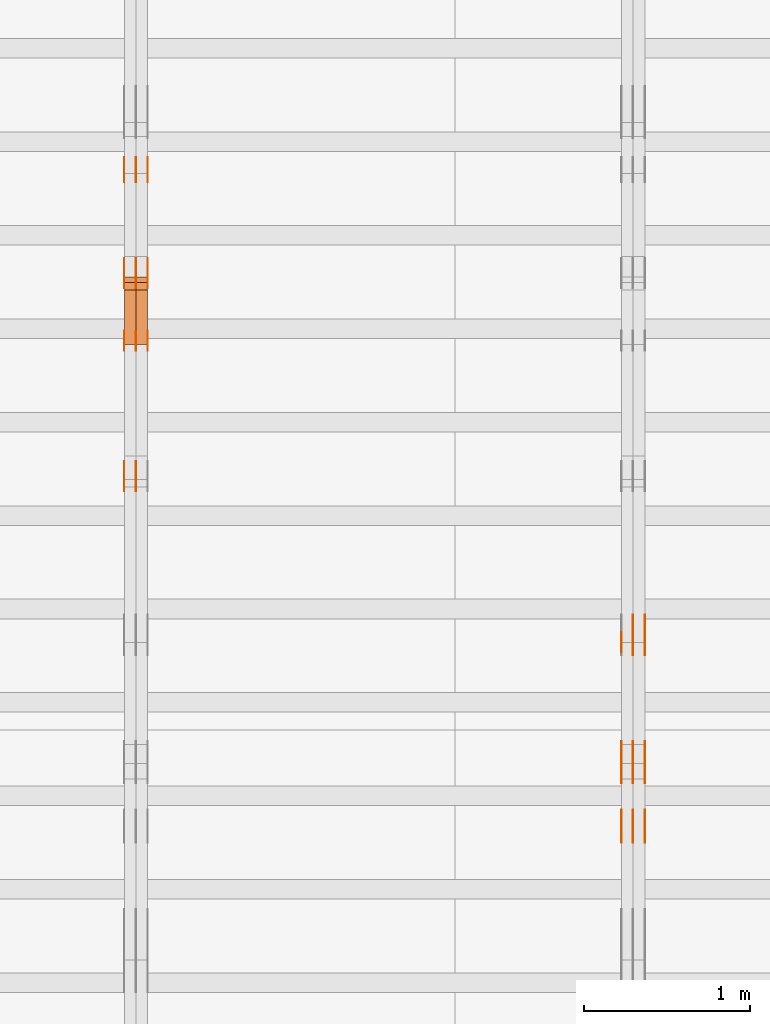
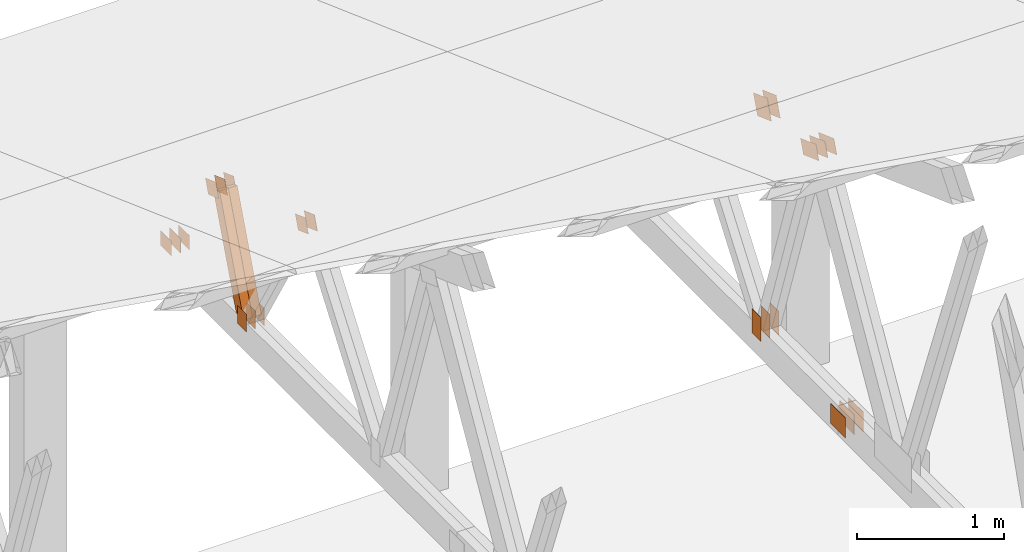
# One storey, part 116 of 189: 32 proxies.
"""IFC2X3 building model written with IfcOpenShell, lengths in millimetres."""

from ifc_helpers import new_model, entity, si_unit, converted_unit, derived_unit, direction, frame, frame_2d, origin, origin_2d_with_axis, place, context, subcontext, project, spatial, polyline, rectangle, outline, extrude, source, transform, mapped, material, type_object, type_shapes, element, save


model = new_model("IFC2X3")

# Units and contexts
model_context = context("Model", 3, precision=0.01, world=origin(), true_north=direction((6.12303176911189e-17, 1.0)))
body_context = subcontext(model_context, "Body", "Model", "MODEL_VIEW")
ifc_project = project(units=[si_unit("LENGTHUNIT", "METRE", prefix="MILLI"), si_unit("AREAUNIT", "SQUARE_METRE"), si_unit("VOLUMEUNIT", "CUBIC_METRE"), converted_unit("PLANEANGLEUNIT", "DEGREE", entity("IfcRatioMeasure", 0.0174532925199433), si_unit("PLANEANGLEUNIT", "RADIAN"), dimensions=[0, 0, 0, 0, 0, 0, 0]), si_unit("MASSUNIT", "GRAM", prefix="KILO"), derived_unit("MASSDENSITYUNIT", [(si_unit("MASSUNIT", "GRAM", prefix="KILO"), 1), (si_unit("LENGTHUNIT", "METRE"), -3)]), si_unit("TIMEUNIT", "SECOND"), si_unit("FREQUENCYUNIT", "HERTZ"), si_unit("THERMODYNAMICTEMPERATUREUNIT", "DEGREE_CELSIUS"), derived_unit("THERMALTRANSMITTANCEUNIT", [(si_unit("MASSUNIT", "GRAM", prefix="KILO"), 1), (si_unit("THERMODYNAMICTEMPERATUREUNIT", "KELVIN"), -1), (si_unit("TIMEUNIT", "SECOND"), -3)]), derived_unit("VOLUMETRICFLOWRATEUNIT", [(si_unit("LENGTHUNIT", "METRE"), 3), (si_unit("TIMEUNIT", "SECOND"), -1)]), si_unit("ELECTRICCURRENTUNIT", "AMPERE"), si_unit("ELECTRICVOLTAGEUNIT", "VOLT"), si_unit("POWERUNIT", "WATT"), si_unit("FORCEUNIT", "NEWTON"), si_unit("ILLUMINANCEUNIT", "LUX"), si_unit("LUMINOUSFLUXUNIT", "LUMEN"), si_unit("LUMINOUSINTENSITYUNIT", "CANDELA"), derived_unit("USERDEFINED", [(si_unit("MASSUNIT", "GRAM", prefix="KILO"), -1), (si_unit("LENGTHUNIT", "METRE"), -2), (si_unit("TIMEUNIT", "SECOND"), 3), (si_unit("LUMINOUSFLUXUNIT", "LUMEN"), 1)]), derived_unit("LINEARVELOCITYUNIT", [(si_unit("LENGTHUNIT", "METRE"), 1), (si_unit("TIMEUNIT", "SECOND"), -1)]), si_unit("PRESSUREUNIT", "PASCAL"), derived_unit("USERDEFINED", [(si_unit("LENGTHUNIT", "METRE"), -2), (si_unit("MASSUNIT", "GRAM", prefix="KILO"), 1), (si_unit("TIMEUNIT", "SECOND"), -2)])], contexts=[model_context])

# Site, building, storey
site_placement = place(None, origin())
site = spatial("IfcSite", under=ifc_project, at=site_placement, CompositionType="ELEMENT")
building_placement = place(site_placement, origin())
building = spatial("IfcBuilding", under=site, at=building_placement, CompositionType="ELEMENT")
storey_placement = place(building_placement, origin())
storey = spatial("IfcBuildingStorey", under=building, at=storey_placement, Name="Default", CompositionType="ELEMENT", Elevation=0.0)

# Proxies
ifc_material_1 = material(Name="IfcSurfaceStyle #74898")
building_element_proxy_type_1 = type_object("IfcBuildingElementProxyType", PredefinedType="NOTDEFINED", material=ifc_material_1)
shared_shape_1 = source(origin(), body_context, "Body", "SweptSolid", [
    extrude(outline(polyline([(-112.499846801582, -59.999986193028), (112.499924372729, -59.999986193028), (112.499888552087, 59.999986193028), (-112.499966123235, 59.999986193028), (-112.499846801582, -59.999986193028)])), frame((112.499989807712, 60.0001003787081, 0.0), z_axis=(0.0, 0.0, 1.0), x_axis=(-1.0, 0.0, 0.0)), (0.0, 0.0, 1.0), 1.3),
])
type_shapes(building_element_proxy_type_1, [shared_shape_1])
proxy_1_placement = place(building_placement, frame((12301.3, 24040.8868138992, 2049.61031693104), z_axis=(-1.0, 0.0, 0.0), x_axis=(0.0, -0.939692620785908, 0.342020143325669)))
element("IfcBuildingElementProxy", 1, at=proxy_1_placement, inside=storey, type_object=building_element_proxy_type_1, material=ifc_material_1, context=body_context, shape_type="MappedRepresentation", body=[
    mapped(shared_shape_1, transform((0.0, 0.0, 0.0), scale=1.0)),
])
ifc_material_2 = material(Name="IfcSurfaceStyle #74841")
building_element_proxy_type_2 = type_object("IfcBuildingElementProxyType", PredefinedType="NOTDEFINED", material=ifc_material_2)
shared_shape_2 = source(origin(), body_context, "Body", "SweptSolid", [
    extrude(outline(polyline([(-112.499846801582, -59.999986193028), (112.499924372729, -59.999986193028), (112.499888552087, 59.999986193028), (-112.499966123235, 59.999986193028), (-112.499846801582, -59.999986193028)])), frame((112.499989807712, 60.0001003787081, 0.0), z_axis=(0.0, 0.0, 1.0), x_axis=(-1.0, 0.0, 0.0)), (0.0, 0.0, 1.0), 1.29999999999998),
])
type_shapes(building_element_proxy_type_2, [shared_shape_2])
proxy_2_placement = place(building_placement, frame((12230.0, 24040.8868138992, 2049.61031693104), z_axis=(-1.0, 0.0, 0.0), x_axis=(0.0, -0.939692620785908, 0.342020143325669)))
element("IfcBuildingElementProxy", 2, at=proxy_2_placement, inside=storey, type_object=building_element_proxy_type_2, material=ifc_material_2, context=body_context, shape_type="MappedRepresentation", body=[
    mapped(shared_shape_2, transform((0.0, 0.0, 0.0), scale=1.0)),
])
ifc_material_3 = material(Name="IfcSurfaceStyle #74784")
building_element_proxy_type_3 = type_object("IfcBuildingElementProxyType", PredefinedType="NOTDEFINED", material=ifc_material_3)
shared_shape_3 = source(origin(), body_context, "Body", "SweptSolid", [
    extrude(outline(polyline([(-112.499846801582, -59.999986193028), (112.499924372729, -59.999986193028), (112.499888552087, 59.999986193028), (-112.499966123235, 59.999986193028), (-112.499846801582, -59.999986193028)])), frame((112.499989807712, 60.0001003787081, 0.0), z_axis=(0.0, 0.0, 1.0), x_axis=(-1.0, 0.0, 0.0)), (0.0, 0.0, 1.0), 1.29999999999998),
])
type_shapes(building_element_proxy_type_3, [shared_shape_3])
proxy_3_placement = place(building_placement, frame((12231.3, 24040.8868138992, 2049.61031693104), z_axis=(-1.0, 0.0, 0.0), x_axis=(0.0, -0.939692620785908, 0.342020143325669)))
element("IfcBuildingElementProxy", 3, at=proxy_3_placement, inside=storey, type_object=building_element_proxy_type_3, material=ifc_material_3, context=body_context, shape_type="MappedRepresentation", body=[
    mapped(shared_shape_3, transform((0.0, 0.0, 0.0), scale=1.0)),
])
ifc_material_4 = material(Name="IfcSurfaceStyle #74727")
building_element_proxy_type_4 = type_object("IfcBuildingElementProxyType", PredefinedType="NOTDEFINED", material=ifc_material_4)
shared_shape_4 = source(origin(), body_context, "Body", "SweptSolid", [
    extrude(outline(polyline([(-112.499846801582, -59.999986193028), (112.499924372729, -59.999986193028), (112.499888552087, 59.999986193028), (-112.499966123235, 59.999986193028), (-112.499846801582, -59.999986193028)])), frame((112.499989807712, 60.0001003787081, 0.0), z_axis=(0.0, 0.0, 1.0), x_axis=(-1.0, 0.0, 0.0)), (0.0, 0.0, 1.0), 1.29999999999999),
])
type_shapes(building_element_proxy_type_4, [shared_shape_4])
proxy_4_placement = place(building_placement, frame((12160.0, 24040.8868138992, 2049.61031693104), z_axis=(-1.0, 0.0, 0.0), x_axis=(0.0, -0.939692620785908, 0.342020143325669)))
element("IfcBuildingElementProxy", 4, at=proxy_4_placement, inside=storey, type_object=building_element_proxy_type_4, material=ifc_material_4, context=body_context, shape_type="MappedRepresentation", body=[
    mapped(shared_shape_4, transform((0.0, 0.0, 0.0), scale=1.0)),
])
ifc_material_5 = material(Name="IfcSurfaceStyle #74670")
building_element_proxy_type_5 = type_object("IfcBuildingElementProxyType", PredefinedType="NOTDEFINED", material=ifc_material_5)
shared_shape_5 = source(origin(), body_context, "Body", "SweptSolid", [
    extrude(rectangle(XDim=200.0, YDim=120.0, at=origin_2d_with_axis()), frame((100.0, 60.0002296775929, 0.0), z_axis=(0.0, 0.0, 1.0), x_axis=(-1.0, 0.0, 0.0)), (0.0, 0.0, 1.0), 1.3),
])
type_shapes(building_element_proxy_type_5, [shared_shape_5])
proxy_5_placement = place(building_placement, frame((12301.3, 24619.3435203224, 145.0), z_axis=(-1.0, 0.0, 0.0), x_axis=(0.0, 0.0, 1.0)))
element("IfcBuildingElementProxy", 5, at=proxy_5_placement, inside=storey, type_object=building_element_proxy_type_5, material=ifc_material_5, context=body_context, shape_type="MappedRepresentation", body=[
    mapped(shared_shape_5, transform((0.0, 0.0, 0.0), scale=1.0)),
])
ifc_material_6 = material(Name="IfcSurfaceStyle #74613")
building_element_proxy_type_6 = type_object("IfcBuildingElementProxyType", PredefinedType="NOTDEFINED", material=ifc_material_6)
shared_shape_6 = source(origin(), body_context, "Body", "SweptSolid", [
    extrude(rectangle(XDim=200.0, YDim=120.0, at=origin_2d_with_axis()), frame((100.0, 60.0002296775929, 0.0), z_axis=(0.0, 0.0, 1.0), x_axis=(-1.0, 0.0, 0.0)), (0.0, 0.0, 1.0), 1.29999999999998),
])
type_shapes(building_element_proxy_type_6, [shared_shape_6])
proxy_6_placement = place(building_placement, frame((12230.0, 24619.3435203224, 145.0), z_axis=(-1.0, 0.0, 0.0), x_axis=(0.0, 0.0, 1.0)))
element("IfcBuildingElementProxy", 6, at=proxy_6_placement, inside=storey, type_object=building_element_proxy_type_6, material=ifc_material_6, context=body_context, shape_type="MappedRepresentation", body=[
    mapped(shared_shape_6, transform((0.0, 0.0, 0.0), scale=1.0)),
])
ifc_material_7 = material(Name="IfcSurfaceStyle #74556")
building_element_proxy_type_7 = type_object("IfcBuildingElementProxyType", PredefinedType="NOTDEFINED", material=ifc_material_7)
shared_shape_7 = source(origin(), body_context, "Body", "SweptSolid", [
    extrude(rectangle(XDim=200.0, YDim=120.0, at=origin_2d_with_axis()), frame((100.0, 60.0002296775929, 0.0), z_axis=(0.0, 0.0, 1.0), x_axis=(-1.0, 0.0, 0.0)), (0.0, 0.0, 1.0), 1.29999999999998),
])
type_shapes(building_element_proxy_type_7, [shared_shape_7])
proxy_7_placement = place(building_placement, frame((12231.3, 24619.3435203224, 145.0), z_axis=(-1.0, 0.0, 0.0), x_axis=(0.0, 0.0, 1.0)))
element("IfcBuildingElementProxy", 7, at=proxy_7_placement, inside=storey, type_object=building_element_proxy_type_7, material=ifc_material_7, context=body_context, shape_type="MappedRepresentation", body=[
    mapped(shared_shape_7, transform((0.0, 0.0, 0.0), scale=1.0)),
])
ifc_material_8 = material(Name="IfcSurfaceStyle #74499")
building_element_proxy_type_8 = type_object("IfcBuildingElementProxyType", PredefinedType="NOTDEFINED", material=ifc_material_8)
shared_shape_8 = source(origin(), body_context, "Body", "SweptSolid", [
    extrude(rectangle(XDim=200.0, YDim=120.0, at=origin_2d_with_axis()), frame((100.0, 60.0002296775929, 0.0), z_axis=(0.0, 0.0, 1.0), x_axis=(-1.0, 0.0, 0.0)), (0.0, 0.0, 1.0), 1.29999999999999),
])
type_shapes(building_element_proxy_type_8, [shared_shape_8])
proxy_8_placement = place(building_placement, frame((12160.0, 24619.3435203224, 145.0), z_axis=(-1.0, 0.0, 0.0), x_axis=(0.0, 0.0, 1.0)))
element("IfcBuildingElementProxy", 8, at=proxy_8_placement, inside=storey, type_object=building_element_proxy_type_8, material=ifc_material_8, context=body_context, shape_type="MappedRepresentation", body=[
    mapped(shared_shape_8, transform((0.0, 0.0, 0.0), scale=1.0)),
])
ifc_material_9 = material(Name="IfcSurfaceStyle #71022")
building_element_proxy_type_9 = type_object("IfcBuildingElementProxyType", PredefinedType="NOTDEFINED", material=ifc_material_9)
shared_shape_9 = source(origin(), body_context, "Body", "SweptSolid", [
    extrude(rectangle(XDim=200.0, YDim=168.0, at=origin_2d_with_axis()), frame((100.0, 84.0, 0.0), z_axis=(0.0, 0.0, 1.0), x_axis=(-1.0, 0.0, 0.0)), (0.0, 0.0, 1.0), 1.3),
])
type_shapes(building_element_proxy_type_9, [shared_shape_9])
proxy_9_placement = place(building_placement, frame((12301.3, 23470.0, 206.5), z_axis=(-1.0, 0.0, 0.0), x_axis=(0.0, 1.0, 0.0)))
element("IfcBuildingElementProxy", 9, at=proxy_9_placement, inside=storey, type_object=building_element_proxy_type_9, material=ifc_material_9, context=body_context, shape_type="MappedRepresentation", body=[
    mapped(shared_shape_9, transform((0.0, 0.0, 0.0), scale=1.0)),
])
ifc_material_10 = material(Name="IfcSurfaceStyle #70965")
building_element_proxy_type_10 = type_object("IfcBuildingElementProxyType", PredefinedType="NOTDEFINED", material=ifc_material_10)
shared_shape_10 = source(origin(), body_context, "Body", "SweptSolid", [
    extrude(rectangle(XDim=200.0, YDim=168.0, at=origin_2d_with_axis()), frame((100.0, 84.0, 0.0), z_axis=(0.0, 0.0, 1.0), x_axis=(-1.0, 0.0, 0.0)), (0.0, 0.0, 1.0), 1.29999999999998),
])
type_shapes(building_element_proxy_type_10, [shared_shape_10])
proxy_10_placement = place(building_placement, frame((12230.0, 23470.0, 206.5), z_axis=(-1.0, 0.0, 0.0), x_axis=(0.0, 1.0, 0.0)))
element("IfcBuildingElementProxy", 10, at=proxy_10_placement, inside=storey, type_object=building_element_proxy_type_10, material=ifc_material_10, context=body_context, shape_type="MappedRepresentation", body=[
    mapped(shared_shape_10, transform((0.0, 0.0, 0.0), scale=1.0)),
])
ifc_material_11 = material(Name="IfcSurfaceStyle #70908")
building_element_proxy_type_11 = type_object("IfcBuildingElementProxyType", PredefinedType="NOTDEFINED", material=ifc_material_11)
shared_shape_11 = source(origin(), body_context, "Body", "SweptSolid", [
    extrude(rectangle(XDim=200.0, YDim=168.0, at=origin_2d_with_axis()), frame((100.0, 84.0, 0.0), z_axis=(0.0, 0.0, 1.0), x_axis=(-1.0, 0.0, 0.0)), (0.0, 0.0, 1.0), 1.29999999999998),
])
type_shapes(building_element_proxy_type_11, [shared_shape_11])
proxy_11_placement = place(building_placement, frame((12231.3, 23470.0, 206.5), z_axis=(-1.0, 0.0, 0.0), x_axis=(0.0, 1.0, 0.0)))
element("IfcBuildingElementProxy", 11, at=proxy_11_placement, inside=storey, type_object=building_element_proxy_type_11, material=ifc_material_11, context=body_context, shape_type="MappedRepresentation", body=[
    mapped(shared_shape_11, transform((0.0, 0.0, 0.0), scale=1.0)),
])
ifc_material_12 = material(Name="IfcSurfaceStyle #70851")
building_element_proxy_type_12 = type_object("IfcBuildingElementProxyType", PredefinedType="NOTDEFINED", material=ifc_material_12)
shared_shape_12 = source(origin(), body_context, "Body", "SweptSolid", [
    extrude(rectangle(XDim=200.0, YDim=168.0, at=origin_2d_with_axis()), frame((100.0, 84.0, 0.0), z_axis=(0.0, 0.0, 1.0), x_axis=(-1.0, 0.0, 0.0)), (0.0, 0.0, 1.0), 1.29999999999999),
])
type_shapes(building_element_proxy_type_12, [shared_shape_12])
proxy_12_placement = place(building_placement, frame((12160.0, 23470.0, 206.5), z_axis=(-1.0, 0.0, 0.0), x_axis=(0.0, 1.0, 0.0)))
element("IfcBuildingElementProxy", 12, at=proxy_12_placement, inside=storey, type_object=building_element_proxy_type_12, material=ifc_material_12, context=body_context, shape_type="MappedRepresentation", body=[
    mapped(shared_shape_12, transform((0.0, 0.0, 0.0), scale=1.0)),
])
ifc_material_13 = material(Name="IfcSurfaceStyle #68862")
building_element_proxy_type_13 = type_object("IfcBuildingElementProxyType", PredefinedType="NOTDEFINED", material=ifc_material_13)
shared_shape_13 = source(origin(), body_context, "Body", "SweptSolid", [
    extrude(outline(polyline([(-99.9999065788418, -84.0000755647729), (99.9999734279406, -84.0000755647729), (99.9999483293475, 84.000075564773), (-100.000015178446, 84.000075564773), (-99.9999065788418, -84.0000755647729)])), frame((100.000157783747, 84.0001144608011, 0.0), z_axis=(0.0, 0.0, 1.0), x_axis=(-1.0, 0.0, 0.0)), (0.0, 0.0, 1.0), 1.3),
])
type_shapes(building_element_proxy_type_13, [shared_shape_13])
proxy_13_placement = place(building_placement, frame((12301.3, 24788.4767593228, 1895.10136879206), z_axis=(-1.0, 0.0, 0.0), x_axis=(0.0, -0.939692620785908, 0.342020143325669)))
element("IfcBuildingElementProxy", 13, at=proxy_13_placement, inside=storey, type_object=building_element_proxy_type_13, material=ifc_material_13, context=body_context, shape_type="MappedRepresentation", body=[
    mapped(shared_shape_13, transform((0.0, 0.0, 0.0), scale=1.0)),
])
ifc_material_14 = material(Name="IfcSurfaceStyle #68805")
building_element_proxy_type_14 = type_object("IfcBuildingElementProxyType", PredefinedType="NOTDEFINED", material=ifc_material_14)
shared_shape_14 = source(origin(), body_context, "Body", "SweptSolid", [
    extrude(outline(polyline([(-99.9999065788418, -84.0000755647729), (99.9999734279406, -84.0000755647729), (99.9999483293475, 84.000075564773), (-100.000015178446, 84.000075564773), (-99.9999065788418, -84.0000755647729)])), frame((100.000157783747, 84.0001144608011, 0.0), z_axis=(0.0, 0.0, 1.0), x_axis=(-1.0, 0.0, 0.0)), (0.0, 0.0, 1.0), 1.29999999999998),
])
type_shapes(building_element_proxy_type_14, [shared_shape_14])
proxy_14_placement = place(building_placement, frame((12230.0, 24788.4767593228, 1895.10136879206), z_axis=(-1.0, 0.0, 0.0), x_axis=(0.0, -0.939692620785908, 0.342020143325669)))
element("IfcBuildingElementProxy", 14, at=proxy_14_placement, inside=storey, type_object=building_element_proxy_type_14, material=ifc_material_14, context=body_context, shape_type="MappedRepresentation", body=[
    mapped(shared_shape_14, transform((0.0, 0.0, 0.0), scale=1.0)),
])
ifc_material_15 = material(Name="IfcSurfaceStyle #68748")
building_element_proxy_type_15 = type_object("IfcBuildingElementProxyType", PredefinedType="NOTDEFINED", material=ifc_material_15)
shared_shape_15 = source(origin(), body_context, "Body", "SweptSolid", [
    extrude(outline(polyline([(-99.9999065788418, -84.0000755647729), (99.9999734279406, -84.0000755647729), (99.9999483293475, 84.000075564773), (-100.000015178446, 84.000075564773), (-99.9999065788418, -84.0000755647729)])), frame((100.000157783747, 84.0001144608011, 0.0), z_axis=(0.0, 0.0, 1.0), x_axis=(-1.0, 0.0, 0.0)), (0.0, 0.0, 1.0), 1.29999999999998),
])
type_shapes(building_element_proxy_type_15, [shared_shape_15])
proxy_15_placement = place(building_placement, frame((12231.3, 24788.4767593228, 1895.10136879206), z_axis=(-1.0, 0.0, 0.0), x_axis=(0.0, -0.939692620785908, 0.342020143325669)))
element("IfcBuildingElementProxy", 15, at=proxy_15_placement, inside=storey, type_object=building_element_proxy_type_15, material=ifc_material_15, context=body_context, shape_type="MappedRepresentation", body=[
    mapped(shared_shape_15, transform((0.0, 0.0, 0.0), scale=1.0)),
])
ifc_material_16 = material(Name="IfcSurfaceStyle #58139")
building_element_proxy_type_16 = type_object("IfcBuildingElementProxyType", PredefinedType="NOTDEFINED", material=ifc_material_16)
shared_shape_16 = source(origin(), body_context, "Body", "SweptSolid", [
    extrude(outline(polyline([(-74.9999475298494, -60.0), (75.0000042257432, -60.0), (74.9999684051025, 60.0), (-75.0000251009963, 60.0), (-74.9999475298494, -60.0)])), frame((75.0000607644577, 60.0000865490217, 0.0), z_axis=(0.0, 0.0, 1.0), x_axis=(-1.0, 0.0, 0.0)), (0.0, 0.0, 1.0), 1.29999999999999),
])
type_shapes(building_element_proxy_type_16, [shared_shape_16])
proxy_16_placement = place(building_placement, frame((9230.0, 25732.0586805394, 1446.84420669249), z_axis=(-1.0, 0.0, 0.0), x_axis=(0.0, -0.939692620785908, 0.342020143325669)))
element("IfcBuildingElementProxy", 16, at=proxy_16_placement, inside=storey, type_object=building_element_proxy_type_16, material=ifc_material_16, context=body_context, shape_type="MappedRepresentation", body=[
    mapped(shared_shape_16, transform((0.0, 0.0, 0.0), scale=1.0)),
])
ifc_material_17 = material(Name="IfcSurfaceStyle #58082")
building_element_proxy_type_17 = type_object("IfcBuildingElementProxyType", PredefinedType="NOTDEFINED", material=ifc_material_17)
shared_shape_17 = source(origin(), body_context, "Body", "SweptSolid", [
    extrude(outline(polyline([(-74.9999475298494, -60.0), (75.0000042257432, -60.0), (74.9999684051025, 60.0), (-75.0000251009963, 60.0), (-74.9999475298494, -60.0)])), frame((75.0000607644577, 60.0000865490217, 0.0), z_axis=(0.0, 0.0, 1.0), x_axis=(-1.0, 0.0, 0.0)), (0.0, 0.0, 1.0), 1.29999999999999),
])
type_shapes(building_element_proxy_type_17, [shared_shape_17])
proxy_17_placement = place(building_placement, frame((9231.3, 25732.0586805394, 1446.84420669249), z_axis=(-1.0, 0.0, 0.0), x_axis=(0.0, -0.939692620785908, 0.342020143325669)))
element("IfcBuildingElementProxy", 17, at=proxy_17_placement, inside=storey, type_object=building_element_proxy_type_17, material=ifc_material_17, context=body_context, shape_type="MappedRepresentation", body=[
    mapped(shared_shape_17, transform((0.0, 0.0, 0.0), scale=1.0)),
])
ifc_material_18 = material(Name="IfcSurfaceStyle #58025")
building_element_proxy_type_18 = type_object("IfcBuildingElementProxyType", PredefinedType="NOTDEFINED", material=ifc_material_18)
shared_shape_18 = source(origin(), body_context, "Body", "SweptSolid", [
    extrude(outline(polyline([(-74.9999475298494, -60.0), (75.0000042257432, -60.0), (74.9999684051025, 60.0), (-75.0000251009963, 60.0), (-74.9999475298494, -60.0)])), frame((75.0000607644577, 60.0000865490217, 0.0), z_axis=(0.0, 0.0, 1.0), x_axis=(-1.0, 0.0, 0.0)), (0.0, 0.0, 1.0), 1.29999999999999),
])
type_shapes(building_element_proxy_type_18, [shared_shape_18])
proxy_18_placement = place(building_placement, frame((9160.0, 25732.0586805394, 1446.84420669249), z_axis=(-1.0, 0.0, 0.0), x_axis=(0.0, -0.939692620785908, 0.342020143325669)))
element("IfcBuildingElementProxy", 18, at=proxy_18_placement, inside=storey, type_object=building_element_proxy_type_18, material=ifc_material_18, context=body_context, shape_type="MappedRepresentation", body=[
    mapped(shared_shape_18, transform((0.0, 0.0, 0.0), scale=1.0)),
])
ifc_material_19 = material(Name="IfcSurfaceStyle #57968")
building_element_proxy_type_19 = type_object("IfcBuildingElementProxyType", PredefinedType="NOTDEFINED", material=ifc_material_19)
shared_shape_19 = source(origin(), body_context, "Body", "SweptSolid", [
    extrude(rectangle(XDim=150.0, YDim=120.0, at=frame_2d((-7.105427357601e-15, 0.0), x_axis=(1.0, 0.0))), frame((75.0, 60.0, 0.0), z_axis=(0.0, 0.0, 1.0), x_axis=(-1.0, 0.0, 0.0)), (0.0, 0.0, 1.0), 1.3),
])
type_shapes(building_element_proxy_type_19, [shared_shape_19])
proxy_19_placement = place(building_placement, frame((9301.3, 26439.0083007813, 170.0), z_axis=(-1.0, 0.0, 0.0), x_axis=(0.0, 0.0, 1.0)))
element("IfcBuildingElementProxy", 19, at=proxy_19_placement, inside=storey, type_object=building_element_proxy_type_19, material=ifc_material_19, context=body_context, shape_type="MappedRepresentation", body=[
    mapped(shared_shape_19, transform((0.0, 0.0, 0.0), scale=1.0)),
])
ifc_material_20 = material(Name="IfcSurfaceStyle #57911")
building_element_proxy_type_20 = type_object("IfcBuildingElementProxyType", PredefinedType="NOTDEFINED", material=ifc_material_20)
shared_shape_20 = source(origin(), body_context, "Body", "SweptSolid", [
    extrude(rectangle(XDim=150.0, YDim=120.0, at=frame_2d((-7.105427357601e-15, 0.0), x_axis=(1.0, 0.0))), frame((75.0, 60.0, 0.0), z_axis=(0.0, 0.0, 1.0), x_axis=(-1.0, 0.0, 0.0)), (0.0, 0.0, 1.0), 1.29999999999999),
])
type_shapes(building_element_proxy_type_20, [shared_shape_20])
proxy_20_placement = place(building_placement, frame((9230.0, 26439.0083007813, 170.0), z_axis=(-1.0, 0.0, 0.0), x_axis=(0.0, 0.0, 1.0)))
element("IfcBuildingElementProxy", 20, at=proxy_20_placement, inside=storey, type_object=building_element_proxy_type_20, material=ifc_material_20, context=body_context, shape_type="MappedRepresentation", body=[
    mapped(shared_shape_20, transform((0.0, 0.0, 0.0), scale=1.0)),
])
ifc_material_21 = material(Name="IfcSurfaceStyle #57854")
building_element_proxy_type_21 = type_object("IfcBuildingElementProxyType", PredefinedType="NOTDEFINED", material=ifc_material_21)
shared_shape_21 = source(origin(), body_context, "Body", "SweptSolid", [
    extrude(rectangle(XDim=150.0, YDim=120.0, at=frame_2d((-7.105427357601e-15, 0.0), x_axis=(1.0, 0.0))), frame((75.0, 60.0, 0.0), z_axis=(0.0, 0.0, 1.0), x_axis=(-1.0, 0.0, 0.0)), (0.0, 0.0, 1.0), 1.29999999999999),
])
type_shapes(building_element_proxy_type_21, [shared_shape_21])
proxy_21_placement = place(building_placement, frame((9231.3, 26439.0083007813, 170.0), z_axis=(-1.0, 0.0, 0.0), x_axis=(0.0, 0.0, 1.0)))
element("IfcBuildingElementProxy", 21, at=proxy_21_placement, inside=storey, type_object=building_element_proxy_type_21, material=ifc_material_21, context=body_context, shape_type="MappedRepresentation", body=[
    mapped(shared_shape_21, transform((0.0, 0.0, 0.0), scale=1.0)),
])
ifc_material_22 = material(Name="IfcSurfaceStyle #57797")
building_element_proxy_type_22 = type_object("IfcBuildingElementProxyType", PredefinedType="NOTDEFINED", material=ifc_material_22)
shared_shape_22 = source(origin(), body_context, "Body", "SweptSolid", [
    extrude(rectangle(XDim=150.0, YDim=120.0, at=frame_2d((-7.105427357601e-15, 0.0), x_axis=(1.0, 0.0))), frame((75.0, 60.0, 0.0), z_axis=(0.0, 0.0, 1.0), x_axis=(-1.0, 0.0, 0.0)), (0.0, 0.0, 1.0), 1.29999999999999),
])
type_shapes(building_element_proxy_type_22, [shared_shape_22])
proxy_22_placement = place(building_placement, frame((9160.0, 26439.0083007813, 170.0), z_axis=(-1.0, 0.0, 0.0), x_axis=(0.0, 0.0, 1.0)))
element("IfcBuildingElementProxy", 22, at=proxy_22_placement, inside=storey, type_object=building_element_proxy_type_22, material=ifc_material_22, context=body_context, shape_type="MappedRepresentation", body=[
    mapped(shared_shape_22, transform((0.0, 0.0, 0.0), scale=1.0)),
])
ifc_material_23 = material(Name="IfcSurfaceStyle #57284")
building_element_proxy_type_23 = type_object("IfcBuildingElementProxyType", PredefinedType="NOTDEFINED", material=ifc_material_23)
shared_shape_23 = source(origin(), body_context, "Body", "SweptSolid", [
    extrude(outline(polyline([(-74.9999684051023, -60.0), (75.0000251009964, -60.0), (74.9999475298495, 60.0), (-75.0000042257435, 60.0), (-74.9999684051023, -60.0)])), frame((75.0000251009964, 60.0000006265238, 0.0), z_axis=(0.0, 0.0, 1.0), x_axis=(-1.0, 0.0, 0.0)), (0.0, 0.0, 1.0), 1.3),
])
type_shapes(building_element_proxy_type_23, [shared_shape_23])
proxy_23_placement = place(building_placement, frame((9301.3, 26956.490053282, 1001.18769055967), z_axis=(-1.0, 0.0, 0.0), x_axis=(0.0, -0.939692620785908, 0.342020143325669)))
element("IfcBuildingElementProxy", 23, at=proxy_23_placement, inside=storey, type_object=building_element_proxy_type_23, material=ifc_material_23, context=body_context, shape_type="MappedRepresentation", body=[
    mapped(shared_shape_23, transform((0.0, 0.0, 0.0), scale=1.0)),
])
ifc_material_24 = material(Name="IfcSurfaceStyle #57227")
building_element_proxy_type_24 = type_object("IfcBuildingElementProxyType", PredefinedType="NOTDEFINED", material=ifc_material_24)
shared_shape_24 = source(origin(), body_context, "Body", "SweptSolid", [
    extrude(outline(polyline([(-74.9999684051023, -60.0), (75.0000251009964, -60.0), (74.9999475298495, 60.0), (-75.0000042257435, 60.0), (-74.9999684051023, -60.0)])), frame((75.0000251009964, 60.0000006265238, 0.0), z_axis=(0.0, 0.0, 1.0), x_axis=(-1.0, 0.0, 0.0)), (0.0, 0.0, 1.0), 1.29999999999999),
])
type_shapes(building_element_proxy_type_24, [shared_shape_24])
proxy_24_placement = place(building_placement, frame((9230.0, 26956.490053282, 1001.18769055967), z_axis=(-1.0, 0.0, 0.0), x_axis=(0.0, -0.939692620785908, 0.342020143325669)))
element("IfcBuildingElementProxy", 24, at=proxy_24_placement, inside=storey, type_object=building_element_proxy_type_24, material=ifc_material_24, context=body_context, shape_type="MappedRepresentation", body=[
    mapped(shared_shape_24, transform((0.0, 0.0, 0.0), scale=1.0)),
])
ifc_material_25 = material(Name="IfcSurfaceStyle #57170")
building_element_proxy_type_25 = type_object("IfcBuildingElementProxyType", PredefinedType="NOTDEFINED", material=ifc_material_25)
shared_shape_25 = source(origin(), body_context, "Body", "SweptSolid", [
    extrude(outline(polyline([(-74.9999684051023, -60.0), (75.0000251009964, -60.0), (74.9999475298495, 60.0), (-75.0000042257435, 60.0), (-74.9999684051023, -60.0)])), frame((75.0000251009964, 60.0000006265238, 0.0), z_axis=(0.0, 0.0, 1.0), x_axis=(-1.0, 0.0, 0.0)), (0.0, 0.0, 1.0), 1.29999999999999),
])
type_shapes(building_element_proxy_type_25, [shared_shape_25])
proxy_25_placement = place(building_placement, frame((9231.3, 26956.490053282, 1001.18769055967), z_axis=(-1.0, 0.0, 0.0), x_axis=(0.0, -0.939692620785908, 0.342020143325669)))
element("IfcBuildingElementProxy", 25, at=proxy_25_placement, inside=storey, type_object=building_element_proxy_type_25, material=ifc_material_25, context=body_context, shape_type="MappedRepresentation", body=[
    mapped(shared_shape_25, transform((0.0, 0.0, 0.0), scale=1.0)),
])
ifc_material_26 = material(Name="IfcSurfaceStyle #57113")
building_element_proxy_type_26 = type_object("IfcBuildingElementProxyType", PredefinedType="NOTDEFINED", material=ifc_material_26)
shared_shape_26 = source(origin(), body_context, "Body", "SweptSolid", [
    extrude(outline(polyline([(-74.9999684051023, -60.0), (75.0000251009964, -60.0), (74.9999475298495, 60.0), (-75.0000042257435, 60.0), (-74.9999684051023, -60.0)])), frame((75.0000251009964, 60.0000006265238, 0.0), z_axis=(0.0, 0.0, 1.0), x_axis=(-1.0, 0.0, 0.0)), (0.0, 0.0, 1.0), 1.29999999999999),
])
type_shapes(building_element_proxy_type_26, [shared_shape_26])
proxy_26_placement = place(building_placement, frame((9160.0, 26956.490053282, 1001.18769055967), z_axis=(-1.0, 0.0, 0.0), x_axis=(0.0, -0.939692620785908, 0.342020143325669)))
element("IfcBuildingElementProxy", 26, at=proxy_26_placement, inside=storey, type_object=building_element_proxy_type_26, material=ifc_material_26, context=body_context, shape_type="MappedRepresentation", body=[
    mapped(shared_shape_26, transform((0.0, 0.0, 0.0), scale=1.0)),
])
ifc_material_27 = material(Name="IfcSurfaceStyle #57056")
building_element_proxy_type_27 = type_object("IfcBuildingElementProxyType", PredefinedType="NOTDEFINED", material=ifc_material_27)
shared_shape_27 = source(origin(), body_context, "Body", "SweptSolid", [
    extrude(rectangle(XDim=150.0, YDim=120.0, at=origin_2d_with_axis()), frame((75.0, 60.0, 0.0), z_axis=(0.0, 0.0, 1.0), x_axis=(-1.0, 0.0, 0.0)), (0.0, 0.0, 1.0), 1.3),
])
type_shapes(building_element_proxy_type_27, [shared_shape_27])
proxy_27_placement = place(building_placement, frame((9301.3, 27607.3129882813, 185.0), z_axis=(-1.0, 0.0, 0.0), x_axis=(0.0, -1.0, 0.0)))
element("IfcBuildingElementProxy", 27, at=proxy_27_placement, inside=storey, type_object=building_element_proxy_type_27, material=ifc_material_27, context=body_context, shape_type="MappedRepresentation", body=[
    mapped(shared_shape_27, transform((0.0, 0.0, 0.0), scale=1.0)),
])
ifc_material_28 = material(Name="IfcSurfaceStyle #56999")
building_element_proxy_type_28 = type_object("IfcBuildingElementProxyType", PredefinedType="NOTDEFINED", material=ifc_material_28)
shared_shape_28 = source(origin(), body_context, "Body", "SweptSolid", [
    extrude(rectangle(XDim=150.0, YDim=120.0, at=origin_2d_with_axis()), frame((75.0, 60.0, 0.0), z_axis=(0.0, 0.0, 1.0), x_axis=(-1.0, 0.0, 0.0)), (0.0, 0.0, 1.0), 1.29999999999999),
])
type_shapes(building_element_proxy_type_28, [shared_shape_28])
proxy_28_placement = place(building_placement, frame((9230.0, 27607.3129882813, 185.0), z_axis=(-1.0, 0.0, 0.0), x_axis=(0.0, -1.0, 0.0)))
element("IfcBuildingElementProxy", 28, at=proxy_28_placement, inside=storey, type_object=building_element_proxy_type_28, material=ifc_material_28, context=body_context, shape_type="MappedRepresentation", body=[
    mapped(shared_shape_28, transform((0.0, 0.0, 0.0), scale=1.0)),
])
ifc_material_29 = material(Name="IfcSurfaceStyle #56942")
building_element_proxy_type_29 = type_object("IfcBuildingElementProxyType", PredefinedType="NOTDEFINED", material=ifc_material_29)
shared_shape_29 = source(origin(), body_context, "Body", "SweptSolid", [
    extrude(rectangle(XDim=150.0, YDim=120.0, at=origin_2d_with_axis()), frame((75.0, 60.0, 0.0), z_axis=(0.0, 0.0, 1.0), x_axis=(-1.0, 0.0, 0.0)), (0.0, 0.0, 1.0), 1.29999999999999),
])
type_shapes(building_element_proxy_type_29, [shared_shape_29])
proxy_29_placement = place(building_placement, frame((9231.3, 27607.3129882813, 185.0), z_axis=(-1.0, 0.0, 0.0), x_axis=(0.0, -1.0, 0.0)))
element("IfcBuildingElementProxy", 29, at=proxy_29_placement, inside=storey, type_object=building_element_proxy_type_29, material=ifc_material_29, context=body_context, shape_type="MappedRepresentation", body=[
    mapped(shared_shape_29, transform((0.0, 0.0, 0.0), scale=1.0)),
])
ifc_material_30 = material(Name="IfcSurfaceStyle #56885")
building_element_proxy_type_30 = type_object("IfcBuildingElementProxyType", PredefinedType="NOTDEFINED", material=ifc_material_30)
shared_shape_30 = source(origin(), body_context, "Body", "SweptSolid", [
    extrude(rectangle(XDim=150.0, YDim=120.0, at=origin_2d_with_axis()), frame((75.0, 60.0, 0.0), z_axis=(0.0, 0.0, 1.0), x_axis=(-1.0, 0.0, 0.0)), (0.0, 0.0, 1.0), 1.29999999999999),
])
type_shapes(building_element_proxy_type_30, [shared_shape_30])
proxy_30_placement = place(building_placement, frame((9160.0, 27607.3129882813, 185.0), z_axis=(-1.0, 0.0, 0.0), x_axis=(0.0, -1.0, 0.0)))
element("IfcBuildingElementProxy", 30, at=proxy_30_placement, inside=storey, type_object=building_element_proxy_type_30, material=ifc_material_30, context=body_context, shape_type="MappedRepresentation", body=[
    mapped(shared_shape_30, transform((0.0, 0.0, 0.0), scale=1.0)),
])
ifc_material_31 = material(Name="IfcSurfaceStyle #49808")
building_element_proxy_type_31 = type_object("IfcBuildingElementProxyType", Name="T1-W14 49806", PredefinedType="NOTDEFINED", material=ifc_material_31)
shared_shape_31 = source(origin(), body_context, "Body", "SweptSolid", [
    extrude(outline(polyline([(-561.981237417233, -47.499947472121), (373.092610496013, -47.499947472121), (373.679602940405, -4.61719047935016e-05), (341.277449358876, 47.4999705580734), (-526.068425378061, 47.4999705580734), (-561.981237417233, -47.499947472121)])), frame((373.679632439416, 47.500120814091, 0.0), z_axis=(0.0, 0.0, 1.0), x_axis=(-1.0, 0.0, 0.0)), (0.0, 0.0, 1.0), 69.9999999999999),
])
type_shapes(building_element_proxy_type_31, [shared_shape_31])
proxy_31_placement = place(building_placement, frame((9300.0, 26895.4809555667, 1086.61918844835), z_axis=(-1.0, 0.0, 0.0), x_axis=(0.0, -0.353606472447933, -0.935394281916951)))
element("IfcBuildingElementProxy", 31, at=proxy_31_placement, inside=storey, type_object=building_element_proxy_type_31, material=ifc_material_31, Name="T1-W14", context=body_context, shape_type="MappedRepresentation", body=[
    mapped(shared_shape_31, transform((0.0, 0.0, 0.0), scale=1.0)),
])
ifc_material_32 = material(Name="IfcSurfaceStyle #49742")
building_element_proxy_type_32 = type_object("IfcBuildingElementProxyType", Name="T1-W14 49740", PredefinedType="NOTDEFINED", material=ifc_material_32)
shared_shape_32 = source(origin(), body_context, "Body", "SweptSolid", [
    extrude(outline(polyline([(-561.981237417233, -47.499947472121), (373.092610496013, -47.499947472121), (373.679602940405, -4.61719047935016e-05), (341.277449358876, 47.4999705580734), (-526.068425378061, 47.4999705580734), (-561.981237417233, -47.499947472121)])), frame((373.679632439416, 47.500120814091, 0.0), z_axis=(0.0, 0.0, 1.0), x_axis=(-1.0, 0.0, 0.0)), (0.0, 0.0, 1.0), 69.9999999999999),
])
type_shapes(building_element_proxy_type_32, [shared_shape_32])
proxy_32_placement = place(building_placement, frame((9230.0, 26895.4809555667, 1086.61918844835), z_axis=(-1.0, 0.0, 0.0), x_axis=(0.0, -0.353606472447933, -0.935394281916951)))
element("IfcBuildingElementProxy", 32, at=proxy_32_placement, inside=storey, type_object=building_element_proxy_type_32, material=ifc_material_32, Name="T1-W14", context=body_context, shape_type="MappedRepresentation", body=[
    mapped(shared_shape_32, transform((0.0, 0.0, 0.0), scale=1.0)),
])

save(model, "model.ifc")
